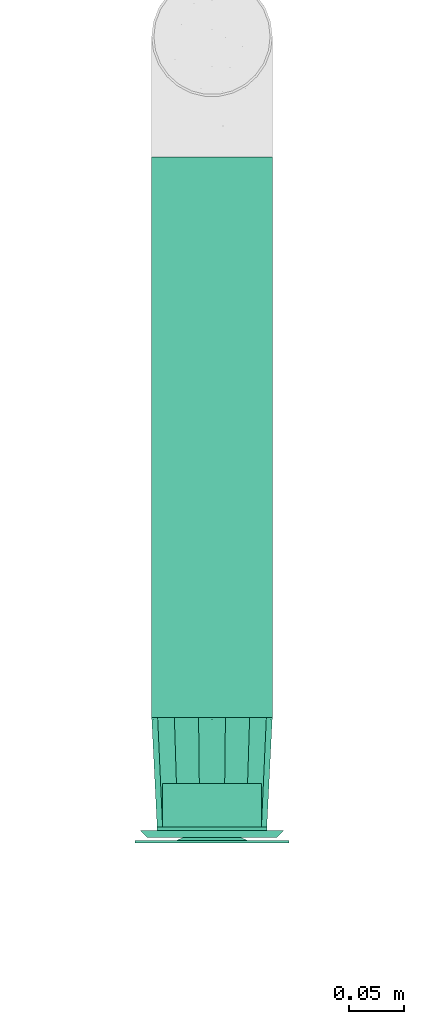
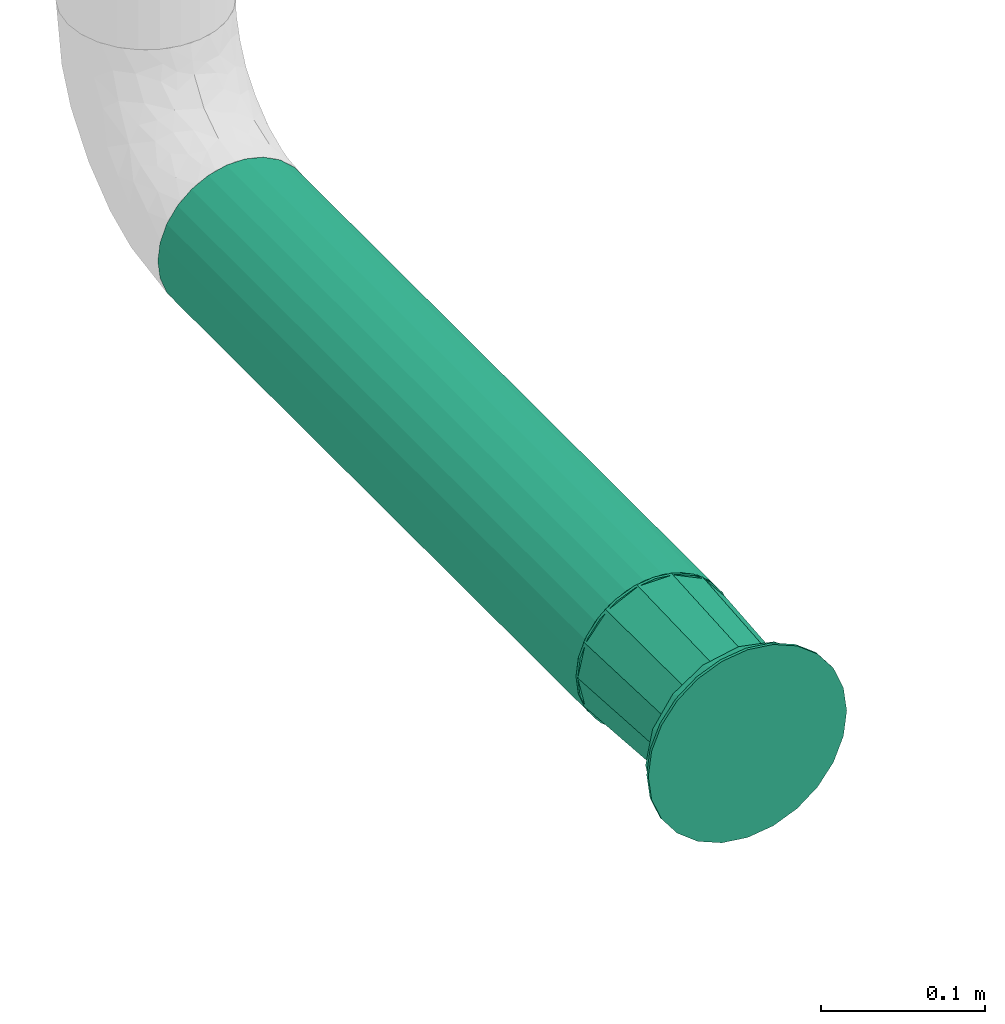
# One storey, part 55 of 123: 1 flow fitting, 1 flow segment, 1 flow terminal.
"""IFC2X3 building model written with IfcOpenShell, lengths in millimetres."""

from ifc_helpers import new_model, entity, si_unit, converted_unit, derived_unit, direction, frame, origin_with_axes, origin_2d_with_axis, place, context, subcontext, project, spatial, hollow_circle, extrude, open_shell, surface_model, source, transform, mapped, material, layer, layer_set, layer_usage, type_object, element, save


model = new_model("IFC2X3")

# Units and contexts
model_context = context("Model", 3, precision=1e-05, world=origin_with_axes(), true_north=direction((0.0, 1.0)))
body_context = subcontext(model_context, "Body", "Model", "MODEL_VIEW")
ifc_project = project(units=[si_unit("AREAUNIT", "SQUARE_METRE"), si_unit("VOLUMEUNIT", "CUBIC_METRE", prefix="DECI"), si_unit("TIMEUNIT", "SECOND"), si_unit("THERMODYNAMICTEMPERATUREUNIT", "DEGREE_CELSIUS"), si_unit("PRESSUREUNIT", "PASCAL"), si_unit("MASSUNIT", "GRAM", prefix="KILO"), si_unit("LENGTHUNIT", "METRE", prefix="MILLI"), si_unit("POWERUNIT", "WATT"), si_unit("ELECTRICCURRENTUNIT", "AMPERE"), si_unit("ELECTRICVOLTAGEUNIT", "VOLT"), derived_unit("VOLUMETRICFLOWRATEUNIT", [(si_unit("VOLUMEUNIT", "CUBIC_METRE", prefix="DECI"), 1), (si_unit("TIMEUNIT", "SECOND"), -1)]), derived_unit("LINEARVELOCITYUNIT", [(si_unit("LENGTHUNIT", "METRE"), 1), (si_unit("TIMEUNIT", "SECOND"), -1)]), derived_unit("MASSDENSITYUNIT", [(si_unit("MASSUNIT", "GRAM", prefix="KILO"), 1), (si_unit("VOLUMEUNIT", "CUBIC_METRE"), -1)]), converted_unit("PLANEANGLEUNIT", "DEGREE", entity("IfcRatioMeasure", 0.01745), si_unit("PLANEANGLEUNIT", "RADIAN"), dimensions=[0, 0, 0, 0, 0, 0, 0])], contexts=[model_context])

# Site, building, storey
site_placement = place(None, origin_with_axes())
site = spatial("IfcSite", under=ifc_project, at=site_placement, CompositionType="ELEMENT")
building_placement = place(site_placement, origin_with_axes())
building = spatial("IfcBuilding", under=site, at=building_placement, Name="mc-building", CompositionType="ELEMENT")
storey_placement = place(building_placement, origin_with_axes())
storey = spatial("IfcBuildingStorey", under=building, at=storey_placement, Name="1. Korrus", CompositionType="ELEMENT", Elevation=0.0)

# Flow terminal
air_terminal_type = type_object("IfcAirTerminalType", Name="100", PredefinedType="NOTDEFINED")
shared_shape_1 = source(origin_with_axes(), body_context, "Body", "SurfaceModel", [
    surface_model("IfcShellBasedSurfaceModel", [(11.2, 18.11733, -67.61481), (11.2, -18.11733, -67.61481), (11.2, 0.0, -70.0), (11.2, 67.61481, -18.11733), (11.2, 35.0, -60.62178), (11.2, 49.49747, -49.49747), (11.2, 60.62178, -35.0), (11.2, -67.61481, 18.11733), (11.2, -49.49747, -49.49747), (11.2, -67.61481, -18.11733), (11.2, -35.0, -60.62178), (11.2, -60.62178, -35.0), (11.2, -70.0, 0.0), (11.2, 18.11733, 67.61481), (11.2, 70.0, 0.0), (11.2, 67.61481, 18.11733), (11.2, 49.49747, 49.49747), (11.2, 60.62178, 35.0), (11.2, 35.0, 60.62178), (11.2, -49.49747, 49.49747), (11.2, -60.62178, 35.0), (11.2, -35.0, 60.62178), (11.2, -18.11733, 67.61481), (11.2, 0.0, 70.0), (9.2, 18.11733, 67.61481), (9.2, -67.61481, 18.11733), (9.2, 0.0, 70.0), (9.2, 49.49747, 49.49747), (9.2, 35.0, 60.62178), (9.2, 60.62178, 35.0), (9.2, 67.61481, 18.11733), (9.2, -35.0, 60.62178), (9.2, -49.49747, 49.49747), (9.2, -18.11733, 67.61481), (9.2, -60.62178, 35.0), (9.2, -67.61481, -18.11733), (9.2, -70.0, 0.0), (9.2, 67.61481, -18.11733), (9.2, 18.11733, -67.61481), (9.2, 49.49747, -49.49747), (9.2, 60.62178, -35.0), (9.2, 35.0, -60.62178), (9.2, -18.11733, -67.61481), (9.2, -49.49747, -49.49747), (9.2, -60.62178, -35.0), (9.2, -35.0, -60.62178), (9.2, 0.0, -70.0), (9.2, 70.0, 0.0), (9.2, 32.75, 0.0), (9.2, -16.375, 28.36233), (9.2, -28.36233, 16.375), (9.2, 16.375, 28.36233), (9.2, 0.0, 32.75), (9.2, 28.36233, 16.375), (9.2, -32.75, 0.0), (9.2, -16.375, -28.36233), (9.2, 16.375, -28.36233), (9.2, 0.0, -32.75), (9.2, 28.36233, -16.375), (9.2, -28.36233, -16.375), (6.2, -21.19625, -15.39997), (6.2, -21.19625, 15.39997), (6.2, 8.09625, 24.91768), (6.2, -8.09625, 24.91768), (6.2, -26.2, 0.0), (6.2, 21.19625, 15.39997), (6.2, -8.09625, -24.91768), (6.2, 21.19625, -15.39997), (6.2, 8.09625, -24.91768), (6.2, 26.2, 0.0), (9.2, 31.06579, -6.28555), (6.2, 23.69812, -7.69999), (6.2, -14.64625, -20.15883), (9.2, -22.36867, -22.36867), (6.2, -23.69812, -7.69999), (9.2, -31.06579, -6.28555), (6.2, 14.64625, -20.15883), (9.2, 8.1875, -30.55617), (6.2, 0.0, -24.91768), (9.2, 22.36867, -22.36867), (9.2, -8.1875, -30.55617), (9.2, -31.06579, 6.28555), (6.2, -23.69812, 7.69999), (6.2, 14.64625, 20.15883), (9.2, 22.36867, 22.36867), (6.2, 23.69812, 7.69999), (9.2, 31.06579, 6.28555), (6.2, -14.64625, 20.15883), (9.2, -8.1875, 30.55617), (6.2, 0.0, 24.91768), (9.2, -22.36867, 22.36867), (9.2, 8.1875, 30.55617), (6.2, -13.11761, 57.472), (6.2, -36.75472, 46.08897), (6.2, -53.11211, 25.57744), (6.2, 36.75472, 46.08897), (6.2, -58.95, 0.0), (6.2, 13.11761, 57.472), (6.2, 53.11211, 25.57744), (6.2, -53.11211, -25.57744), (6.2, -36.75472, -46.08897), (6.2, -13.11761, -57.472), (6.2, 58.95, 0.0), (6.2, 53.11211, -25.57744), (6.2, 13.11761, -57.472), (6.2, 36.75472, -46.08897), (0.0, -60.51411, 25.06576), (0.0, 0.0, 65.5), (0.0, 25.06576, 60.51411), (0.0, 46.3155, 46.3155), (0.0, 60.51411, 25.06576), (0.0, -46.3155, 46.3155), (0.0, -25.06576, 60.51411), (0.0, 0.0, -65.5), (0.0, -65.5, 0.0), (0.0, 65.5, 0.0), (0.0, 60.51411, -25.06576), (0.0, 46.3155, -46.3155), (0.0, 25.06576, -60.51411), (0.0, -46.3155, -46.3155), (0.0, -60.51411, -25.06576), (0.0, -25.06576, -60.51411), (6.2, 56.03105, -12.78872), (0.0, 53.4148, -35.69063), (0.0, 35.69063, -53.4148), (6.2, 24.93616, -51.78048), (0.0, -12.53288, -63.00706), (6.2, 0.0, -57.472), (0.0, -35.69063, -53.4148), (0.0, 63.00706, -12.53288), (6.2, 44.93342, -35.83321), (6.2, -24.93616, -51.78048), (6.2, -44.93342, -35.83321), (0.0, -53.4148, -35.69063), (0.0, 12.53288, -63.00706), (6.2, -56.03105, -12.78872), (0.0, -63.00706, -12.53288), (6.2, -56.03105, 12.78872), (0.0, -53.4148, 35.69063), (0.0, -35.69063, 53.4148), (6.2, -24.93616, 51.78048), (0.0, 12.53288, 63.00706), (6.2, 0.0, 57.472), (0.0, 35.69063, 53.4148), (0.0, -63.00706, 12.53288), (6.2, -44.93342, 35.83321), (6.2, 24.93616, 51.78048), (6.2, 44.93342, 35.83321), (0.0, 53.4148, 35.69063), (0.0, -12.53288, 63.00706), (6.2, 56.03105, 12.78872), (0.0, 63.00706, 12.53288), (-3.1, 12.94095, 48.29629), (-3.1, -35.35534, 35.35534), (-3.1, 0.0, 50.0), (-3.1, 35.35534, 35.35534), (-3.1, 25.0, 43.30127), (-3.1, -43.30127, 25.0), (-3.1, 43.30127, 25.0), (-3.1, -48.29629, -12.94095), (-3.1, -12.94095, 48.29629), (-3.1, -25.0, 43.30127), (-3.1, -50.0, 0.0), (-3.1, -48.29629, 12.94095), (-3.1, 48.29629, 12.94095), (-3.1, 12.94095, -48.29629), (-3.1, 50.0, 0.0), (-3.1, 48.29629, -12.94095), (-3.1, 35.35534, -35.35534), (-3.1, 43.30127, -25.0), (-3.1, 25.0, -43.30127), (-3.1, 0.0, -50.0), (-3.1, -35.35534, -35.35534), (-3.1, -43.30127, -25.0), (-3.1, -25.0, -43.30127), (-3.1, -12.94095, -48.29629), (0.0, 25.0, -43.30127), (0.0, 0.0, -50.0), (0.0, 12.94095, -48.29629), (0.0, 48.29629, -12.94095), (0.0, 35.35534, -35.35534), (0.0, -25.0, -43.30127), (0.0, 43.30127, -25.0), (0.0, -50.0, 0.0), (0.0, -12.94095, -48.29629), (0.0, -35.35534, -35.35534), (0.0, -48.29629, -12.94095), (0.0, -43.30127, -25.0), (0.0, 50.0, 0.0), (0.0, 43.30127, 25.0), (0.0, 12.94095, 48.29629), (0.0, 35.35534, 35.35534), (0.0, 25.0, 43.30127), (0.0, 0.0, 50.0), (0.0, -35.35534, 35.35534), (0.0, -43.30127, 25.0), (0.0, -48.29629, 12.94095), (0.0, -12.94095, 48.29629), (0.0, -25.0, 43.30127), (0.0, 48.29629, 12.94095), (-43.1, 0.0, 45.0), (-43.1, 11.64686, 43.46666), (-43.1, 22.5, 38.97115), (-43.1, -11.64686, 43.46666), (-43.1, 38.97115, 22.5), (-43.1, 43.46666, 11.64686), (-43.1, 31.81981, 31.81981), (-43.1, -22.5, 38.97115), (-43.1, -43.46666, 11.64686), (-43.1, -31.81981, 31.81981), (-43.1, -38.97115, 22.5), (-43.1, -45.0, 0.0), (-43.1, -43.46666, -11.64686), (-43.1, 45.0, 0.0), (-43.1, 43.46666, -11.64686), (-43.1, 38.97115, -22.5), (-43.1, 31.81981, -31.81981), (-43.1, 22.5, -38.97115), (-43.1, 11.64686, -43.46666), (-43.1, -31.81981, -31.81981), (-43.1, -38.97115, -22.5), (-43.1, -22.5, -38.97115), (-43.1, 0.0, -45.0), (-43.1, -11.64686, -43.46666), (-3.1, 22.5, -38.97115), (-3.1, 0.0, -45.0), (-3.1, 11.64686, -43.46666), (-3.1, 31.81981, -31.81981), (-3.1, -22.5, -38.97115), (-3.1, 38.97115, -22.5), (-3.1, 43.46666, -11.64686), (-3.1, 45.0, 0.0), (-3.1, -45.0, 0.0), (-3.1, -11.64686, -43.46666), (-3.1, -31.81981, -31.81981), (-3.1, -43.46666, -11.64686), (-3.1, -38.97115, -22.5), (-3.1, 0.0, 45.0), (-3.1, 43.46666, 11.64686), (-3.1, 38.97115, 22.5), (-3.1, 22.5, 38.97115), (-3.1, 31.81981, 31.81981), (-3.1, 11.64686, 43.46666), (-3.1, -11.64686, 43.46666), (-3.1, -43.46666, 11.64686), (-3.1, -31.81981, 31.81981), (-3.1, -38.97115, 22.5), (-3.1, -22.5, 38.97115)], [open_shell([[[0, 1, 2]], [[3, 0, 4]], [[5, 6, 3]], [[5, 3, 4]], [[7, 1, 0]], [[8, 7, 9]], [[10, 7, 8]], [[8, 9, 11]], [[12, 9, 7]], [[1, 7, 10]], [[7, 0, 3]], [[13, 14, 15]], [[16, 15, 17]], [[16, 18, 13]], [[16, 13, 15]], [[14, 13, 7]], [[7, 19, 20]], [[19, 7, 21]], [[7, 22, 21]], [[22, 7, 23]], [[7, 13, 23]], [[14, 7, 3]], [[24, 25, 26]], [[27, 24, 28]], [[27, 29, 30]], [[27, 30, 24]], [[25, 24, 30]], [[31, 25, 32]], [[25, 31, 33]], [[32, 25, 34]], [[33, 26, 25]], [[25, 35, 36]], [[25, 30, 37]], [[25, 37, 38]], [[39, 37, 40]], [[39, 41, 38]], [[39, 38, 37]], [[38, 42, 25]], [[35, 43, 44]], [[35, 25, 43]], [[45, 43, 25]], [[42, 45, 25]], [[38, 46, 42]], [[37, 30, 47]], [[35, 9, 36]], [[44, 11, 35]], [[10, 43, 45]], [[44, 43, 8]], [[1, 45, 42]], [[35, 11, 9]], [[9, 12, 36]], [[1, 10, 45]], [[8, 43, 10]], [[8, 11, 44]], [[2, 1, 42]], [[42, 46, 2]], [[38, 0, 46]], [[41, 4, 38]], [[6, 39, 40]], [[41, 39, 5]], [[3, 40, 37]], [[41, 5, 4]], [[4, 0, 38]], [[14, 3, 37]], [[6, 40, 3]], [[6, 5, 39]], [[47, 14, 37]], [[46, 0, 2]], [[30, 15, 47]], [[29, 17, 30]], [[18, 27, 28]], [[29, 27, 16]], [[13, 28, 24]], [[30, 17, 15]], [[15, 14, 47]], [[13, 18, 28]], [[16, 27, 18]], [[16, 17, 29]], [[23, 13, 24]], [[24, 26, 23]], [[33, 22, 26]], [[31, 21, 33]], [[20, 32, 34]], [[31, 32, 19]], [[7, 34, 25]], [[31, 19, 21]], [[21, 22, 33]], [[12, 7, 25]], [[20, 34, 7]], [[20, 19, 32]], [[36, 12, 25]], [[26, 22, 23]], [[48, 49, 50]], [[48, 51, 49]], [[49, 51, 52]], [[53, 51, 48]], [[48, 50, 54]], [[54, 55, 48]], [[56, 55, 57]], [[55, 58, 48]], [[58, 55, 56]], [[55, 54, 59]], [[60, 61, 62]], [[62, 61, 63]], [[64, 61, 60]], [[62, 65, 66]], [[67, 68, 65]], [[66, 60, 62]], [[65, 68, 66]], [[69, 67, 65]], [[69, 48, 70]], [[58, 71, 70]], [[72, 73, 60]], [[59, 74, 60]], [[75, 64, 74]], [[56, 68, 76]], [[72, 66, 55]], [[73, 72, 55]], [[68, 77, 78]], [[64, 75, 54]], [[59, 75, 74]], [[70, 71, 69]], [[67, 79, 76]], [[80, 55, 66]], [[68, 56, 77]], [[56, 76, 79]], [[79, 67, 58]], [[71, 58, 67]], [[80, 78, 57]], [[77, 57, 78]], [[66, 78, 80]], [[59, 60, 73]], [[64, 54, 81]], [[50, 82, 81]], [[83, 84, 65]], [[53, 85, 65]], [[86, 69, 85]], [[49, 63, 87]], [[83, 62, 51]], [[84, 83, 51]], [[63, 88, 89]], [[69, 86, 48]], [[53, 86, 85]], [[81, 82, 64]], [[61, 90, 87]], [[91, 51, 62]], [[63, 49, 88]], [[49, 87, 90]], [[90, 61, 50]], [[82, 50, 61]], [[91, 89, 52]], [[88, 52, 89]], [[62, 89, 91]], [[53, 65, 84]], [[92, 93, 94]], [[95, 94, 96]], [[97, 92, 95]], [[95, 92, 94]], [[96, 98, 95]], [[96, 99, 98]], [[99, 100, 101]], [[101, 102, 98]], [[102, 101, 103]], [[104, 105, 103]], [[101, 104, 103]], [[101, 98, 99]], [[106, 107, 108]], [[109, 110, 108]], [[106, 108, 110]], [[111, 112, 106]], [[106, 112, 107]], [[106, 113, 114]], [[106, 110, 113]], [[115, 116, 117]], [[117, 113, 110]], [[113, 117, 118]], [[114, 119, 120]], [[121, 119, 114]], [[121, 114, 113]], [[115, 117, 110]], [[103, 116, 122]], [[123, 116, 103]], [[124, 125, 118]], [[101, 126, 127]], [[100, 119, 128]], [[102, 122, 129]], [[103, 130, 123]], [[102, 129, 115]], [[113, 127, 126]], [[125, 124, 105]], [[130, 105, 117]], [[118, 125, 104]], [[124, 117, 105]], [[131, 100, 128]], [[119, 100, 132]], [[133, 99, 120]], [[134, 118, 104]], [[122, 116, 129]], [[127, 134, 104]], [[131, 121, 101]], [[99, 133, 132]], [[128, 121, 131]], [[130, 117, 123]], [[101, 121, 126]], [[99, 135, 120]], [[96, 136, 135]], [[136, 120, 135]], [[134, 127, 113]], [[133, 119, 132]], [[136, 96, 114]], [[94, 106, 137]], [[138, 106, 94]], [[139, 140, 112]], [[97, 141, 142]], [[95, 109, 143]], [[96, 137, 144]], [[94, 145, 138]], [[96, 144, 114]], [[107, 142, 141]], [[140, 139, 93]], [[145, 93, 111]], [[112, 140, 92]], [[139, 111, 93]], [[146, 95, 143]], [[109, 95, 147]], [[148, 98, 110]], [[149, 112, 92]], [[137, 106, 144]], [[142, 149, 92]], [[146, 108, 97]], [[98, 148, 147]], [[143, 108, 146]], [[145, 111, 138]], [[97, 108, 141]], [[98, 150, 110]], [[102, 151, 150]], [[151, 110, 150]], [[149, 142, 107]], [[148, 109, 147]], [[151, 102, 115]], [[152, 153, 154]], [[155, 152, 156]], [[157, 152, 158]], [[158, 152, 155]], [[158, 159, 157]], [[160, 153, 161]], [[160, 154, 153]], [[157, 162, 163]], [[153, 152, 157]], [[157, 159, 162]], [[158, 164, 159]], [[165, 166, 167]], [[168, 167, 169]], [[170, 165, 167]], [[170, 167, 168]], [[166, 165, 171]], [[159, 172, 173]], [[172, 159, 174]], [[174, 171, 175]], [[159, 164, 174]], [[166, 171, 174]], [[174, 164, 166]], [[176, 177, 178]], [[179, 176, 180]], [[176, 179, 181]], [[179, 180, 182]], [[179, 183, 181]], [[177, 181, 184]], [[177, 176, 181]], [[185, 186, 187]], [[186, 185, 181]], [[181, 183, 186]], [[183, 179, 188]], [[183, 188, 189]], [[190, 189, 191]], [[189, 190, 183]], [[190, 191, 192]], [[193, 194, 190]], [[183, 195, 196]], [[183, 190, 195]], [[194, 197, 198]], [[194, 195, 190]], [[197, 194, 193]], [[189, 188, 199]], [[164, 199, 166]], [[158, 189, 164]], [[192, 155, 156]], [[158, 155, 191]], [[190, 156, 152]], [[164, 189, 199]], [[199, 188, 166]], [[190, 192, 156]], [[191, 155, 192]], [[191, 189, 158]], [[193, 190, 152]], [[152, 154, 193]], [[160, 197, 154]], [[161, 198, 160]], [[195, 153, 157]], [[161, 153, 194]], [[196, 157, 163]], [[161, 194, 198]], [[198, 197, 160]], [[183, 196, 163]], [[195, 157, 196]], [[195, 194, 153]], [[162, 183, 163]], [[154, 197, 193]], [[159, 186, 162]], [[173, 187, 159]], [[181, 172, 174]], [[173, 172, 185]], [[184, 174, 175]], [[159, 187, 186]], [[186, 183, 162]], [[184, 181, 174]], [[185, 172, 181]], [[185, 187, 173]], [[177, 184, 175]], [[175, 171, 177]], [[165, 178, 171]], [[170, 176, 165]], [[182, 168, 169]], [[170, 168, 180]], [[179, 169, 167]], [[170, 180, 176]], [[176, 178, 165]], [[188, 179, 167]], [[182, 169, 179]], [[182, 180, 168]], [[166, 188, 167]], [[171, 178, 177]], [[200, 201, 202]], [[203, 200, 202]], [[204, 205, 202]], [[204, 202, 206]], [[203, 202, 205]], [[207, 208, 209]], [[207, 203, 205]], [[209, 208, 210]], [[211, 208, 212]], [[208, 207, 212]], [[207, 205, 212]], [[213, 214, 215]], [[205, 215, 212]], [[212, 216, 217]], [[216, 212, 215]], [[218, 219, 217]], [[212, 219, 220]], [[212, 217, 219]], [[221, 222, 223]], [[222, 221, 219]], [[218, 222, 219]], [[215, 205, 213]], [[224, 225, 226]], [[227, 228, 224]], [[229, 230, 231]], [[228, 227, 229]], [[229, 232, 228]], [[225, 228, 233]], [[225, 224, 228]], [[234, 235, 236]], [[235, 234, 228]], [[228, 232, 235]], [[232, 229, 231]], [[237, 238, 239]], [[240, 239, 241]], [[240, 242, 237]], [[240, 237, 239]], [[238, 237, 243]], [[244, 245, 246]], [[247, 244, 232]], [[244, 247, 245]], [[232, 238, 247]], [[238, 243, 247]], [[238, 232, 231]], [[205, 238, 213]], [[204, 239, 205]], [[240, 206, 202]], [[204, 206, 241]], [[242, 202, 201]], [[205, 239, 238]], [[238, 231, 213]], [[240, 202, 242]], [[241, 206, 240]], [[241, 239, 204]], [[201, 237, 242]], [[201, 200, 237]], [[243, 203, 207]], [[209, 247, 207]], [[246, 210, 208]], [[209, 210, 245]], [[244, 208, 211]], [[203, 243, 200]], [[207, 247, 243]], [[200, 243, 237]], [[209, 245, 247]], [[210, 246, 245]], [[244, 246, 208]], [[211, 232, 244]], [[212, 235, 211]], [[220, 236, 212]], [[228, 219, 221]], [[220, 219, 234]], [[233, 221, 223]], [[212, 236, 235]], [[235, 232, 211]], [[233, 228, 221]], [[234, 219, 228]], [[234, 236, 220]], [[225, 233, 223]], [[223, 222, 225]], [[226, 218, 217]], [[216, 224, 217]], [[229, 215, 214]], [[216, 215, 227]], [[230, 214, 213]], [[218, 226, 222]], [[217, 224, 226]], [[222, 226, 225]], [[216, 227, 224]], [[215, 229, 227]], [[230, 229, 214]], [[213, 231, 230]]])]),
])
flow_terminal_placement = place(storey_placement, frame((8766.57414, 12939.66532, 2300.0), z_axis=(0.0, 0.0, 1.0), x_axis=(0.0, -1.0, 0.0)))
element("IfcFlowTerminal", 1, at=flow_terminal_placement, inside=storey, type_object=air_terminal_type, Name="100", context=body_context, shape_type="MappedRepresentation", body=[
    mapped(shared_shape_1, transform((0.0, 0.0, 0.0), scale=1.0)),
])

# Flow segment
ifc_material = material(Name="FZ1")
ifc_layer = layer(ifc_material, 0.0)
ifc_layer_set = layer_set([ifc_layer], Name="FZ1")
ifc_layer_usage = layer_usage(ifc_layer_set, "AXIS1", "POSITIVE", 0.0)
duct_segment_type = type_object("IfcDuctSegmentType", PredefinedType="RIGIDSEGMENT")
shared_shape_2 = source(origin_with_axes(), body_context, "Body", "SweptSolid", [
    extrude(hollow_circle(Radius=55.0, WallThickness=2.0, at=origin_2d_with_axis()), frame((0.0, 0.0, 0.0), z_axis=(1.0, 0.0, 0.0), x_axis=(0.0, 1.0, 0.0)), (0.0, 0.0, 1.0), 510.8),
])
flow_segment_placement = place(storey_placement, frame((8766.57414, 13042.76532, 2300.0), z_axis=(0.0, 0.0, 1.0), x_axis=(0.0, 1.0, 0.0)))
element("IfcFlowSegment", 2, at=flow_segment_placement, inside=storey, type_object=duct_segment_type, material=ifc_layer_usage, context=body_context, shape_type="MappedRepresentation", body=[
    mapped(shared_shape_2, transform((0.0, 0.0, 0.0), scale=1.0)),
])

# Flow fitting
duct_fitting_type = type_object("IfcDuctFittingType", PredefinedType="TRANSITION")
shared_shape_3 = source(origin_with_axes(), body_context, "Body", "SurfaceModel", [
    surface_model("IfcShellBasedSurfaceModel", [(0.0, 12.94095, 48.29629), (0.0, -35.35534, 35.35534), (0.0, 0.0, 50.0), (0.0, 35.35534, 35.35534), (0.0, 25.0, 43.30127), (0.0, 43.30127, 25.0), (0.0, 48.29629, 12.94095), (0.0, -12.94095, 48.29629), (0.0, -25.0, 43.30127), (0.0, -48.29629, 12.94095), (0.0, -43.30127, 25.0), (0.0, -25.0, -43.30127), (0.0, -48.29629, -12.94095), (0.0, -50.0, 0.0), (0.0, 48.29629, -12.94095), (0.0, 12.94095, -48.29629), (0.0, 43.30127, -25.0), (0.0, 35.35534, -35.35534), (0.0, 25.0, -43.30127), (0.0, -35.35534, -35.35534), (0.0, -43.30127, -25.0), (0.0, -12.94095, -48.29629), (0.0, 0.0, -50.0), (0.0, 50.0, 0.0), (100.0, -55.0, 0.0), (100.0, -12.23865, 53.62104), (100.0, -34.29194, 43.00073), (100.0, 49.55329, -23.86361), (100.0, 12.23865, 53.62104), (100.0, 34.29194, 43.00073), (100.0, 55.0, 0.0), (100.0, 49.55329, 23.86361), (100.0, -49.55329, 23.86361), (100.0, 12.23865, -53.62104), (100.0, -49.55329, -23.86361), (100.0, -34.29194, -43.00073), (100.0, 34.29194, -43.00073), (100.0, -12.23865, -53.62104), (0.0, 11.12605, 48.7464), (0.0, -11.12605, 48.7464), (0.0, 31.17449, 39.09157), (0.0, -45.04844, -21.69419), (0.0, -45.04844, 21.69419), (0.0, -31.17449, 39.09157), (0.0, 45.04844, 21.69419), (0.0, 45.04844, -21.69419), (0.0, 31.17449, -39.09157), (0.0, -31.17449, -39.09157), (0.0, -11.12605, -48.7464), (0.0, 11.12605, -48.7464), (0.0, -47.52422, -10.84709), (100.0, -41.92261, -33.43217), (0.0, -38.11147, -30.39288), (100.0, 41.92261, -33.43217), (0.0, 38.11147, -30.39288), (0.0, -21.15027, -43.91899), (100.0, -23.2653, -48.31088), (100.0, -52.32388, -11.72483), (100.0, 0.0, -53.62104), (0.0, 0.0, -48.7464), (100.0, 23.2653, -48.31088), (0.0, 21.15027, -43.91899), (100.0, 52.32388, -11.72483), (0.0, 47.52422, -10.84709), (0.0, 47.52422, 10.84709), (100.0, 41.92261, 33.43217), (0.0, 38.11147, 30.39288), (100.0, -41.92261, 33.43217), (0.0, -38.11147, 30.39288), (0.0, 21.15027, 43.91899), (100.0, 23.2653, 48.31088), (100.0, 52.32388, 11.72483), (100.0, 0.0, 53.62104), (0.0, 0.0, 48.7464), (100.0, -23.2653, 48.31088), (0.0, -21.15027, 43.91899), (100.0, -52.32388, 11.72483), (0.0, -47.52422, 10.84709), (100.0, 27.5, -47.63139), (100.0, 0.0, -55.0), (100.0, 14.23505, -53.12592), (100.0, 38.89087, -38.89087), (100.0, -27.5, -47.63139), (100.0, 47.63139, -27.5), (100.0, 53.12592, -14.23505), (100.0, -14.23505, -53.12592), (100.0, -47.63139, -27.5), (100.0, -38.89087, -38.89087), (100.0, -53.12592, -14.23505), (100.0, 53.12592, 14.23505), (100.0, 47.63139, 27.5), (100.0, 27.5, 47.63139), (100.0, 38.89087, 38.89087), (100.0, 14.23505, 53.12592), (100.0, 0.0, 55.0), (100.0, -47.63139, 27.5), (100.0, -53.12592, 14.23505), (100.0, -27.5, 47.63139), (100.0, -38.89087, 38.89087), (100.0, -14.23505, 53.12592), (98.0, 0.0, 55.0), (98.0, 14.23505, 53.12592), (98.0, 27.5, 47.63139), (98.0, 38.89087, 38.89087), (98.0, 47.63139, 27.5), (98.0, -47.63139, 27.5), (98.0, 53.12592, -14.23505), (98.0, -27.5, 47.63139), (98.0, -14.23505, 53.12592), (98.0, -38.89087, 38.89087), (98.0, -55.0, 0.0), (98.0, -53.12592, 14.23505), (98.0, 53.12592, 14.23505), (98.0, 47.63139, -27.5), (98.0, -27.5, -47.63139), (98.0, 0.0, -55.0), (98.0, 38.89087, -38.89087), (98.0, 27.5, -47.63139), (98.0, 14.23505, -53.12592), (98.0, -47.63139, -27.5), (98.0, -38.89087, -38.89087), (98.0, -53.12592, -14.23505), (98.0, -14.23505, -53.12592), (98.0, 55.0, 0.0), (2.0, 12.94095, -48.29629), (2.0, 25.0, -43.30127), (2.0, 35.35534, -35.35534), (2.0, 43.30127, -25.0), (2.0, 48.29629, -12.94095), (2.0, 0.0, -50.0), (2.0, 50.0, 0.0), (2.0, -25.0, -43.30127), (2.0, -12.94095, -48.29629), (2.0, -35.35534, -35.35534), (2.0, -48.29629, -12.94095), (2.0, -43.30127, -25.0), (2.0, -48.29629, 12.94095), (2.0, 48.29629, 12.94095), (2.0, 43.30127, 25.0), (2.0, 35.35534, 35.35534), (2.0, -35.35534, 35.35534), (2.0, 12.94095, 48.29629), (2.0, 25.0, 43.30127), (2.0, 0.0, 50.0), (2.0, -43.30127, 25.0), (2.0, -50.0, 0.0), (2.0, -12.94095, 48.29629), (2.0, -25.0, 43.30127)], [open_shell([[[0, 1, 2]], [[3, 0, 4]], [[3, 5, 6]], [[0, 3, 1]], [[6, 1, 3]], [[7, 1, 8]], [[7, 2, 1]], [[1, 9, 10]], [[9, 1, 11]], [[12, 13, 9]], [[11, 1, 6]], [[6, 14, 11]], [[15, 14, 16]], [[17, 18, 15]], [[17, 15, 16]], [[11, 14, 15]], [[12, 19, 20]], [[19, 12, 11]], [[15, 21, 11]], [[12, 9, 11]], [[22, 21, 15]], [[14, 6, 23]], [[24, 25, 26]], [[25, 27, 28]], [[29, 28, 27]], [[27, 30, 31]], [[31, 29, 27]], [[24, 26, 32]], [[33, 24, 34]], [[33, 34, 35]], [[36, 27, 33]], [[33, 27, 24]], [[35, 37, 33]], [[24, 27, 25]], [[38, 23, 39]], [[40, 23, 38]], [[41, 42, 43]], [[41, 13, 42]], [[23, 43, 39]], [[40, 44, 23]], [[41, 23, 45]], [[41, 45, 46]], [[47, 41, 48]], [[49, 48, 41]], [[41, 46, 49]], [[23, 41, 43]], [[34, 50, 41]], [[47, 51, 52]], [[45, 27, 53]], [[36, 54, 53]], [[55, 48, 56]], [[34, 57, 50]], [[57, 13, 50]], [[13, 57, 24]], [[55, 35, 47]], [[35, 51, 47]], [[51, 41, 52]], [[58, 59, 49]], [[60, 61, 46]], [[37, 59, 58]], [[62, 63, 23]], [[35, 55, 56]], [[23, 30, 62]], [[53, 54, 45]], [[48, 37, 56]], [[33, 49, 61]], [[49, 33, 58]], [[54, 36, 46]], [[63, 27, 45]], [[34, 41, 51]], [[33, 61, 60]], [[48, 59, 37]], [[27, 63, 62]], [[46, 36, 60]], [[31, 64, 44]], [[40, 65, 66]], [[42, 32, 67]], [[26, 68, 67]], [[69, 38, 70]], [[31, 71, 64]], [[71, 23, 64]], [[23, 71, 30]], [[69, 29, 40]], [[29, 65, 40]], [[65, 44, 66]], [[72, 73, 39]], [[74, 75, 43]], [[28, 73, 72]], [[76, 77, 13]], [[29, 69, 70]], [[13, 24, 76]], [[67, 68, 42]], [[38, 28, 70]], [[25, 39, 75]], [[39, 25, 72]], [[68, 26, 43]], [[77, 32, 42]], [[31, 44, 65]], [[25, 75, 74]], [[38, 73, 28]], [[32, 77, 76]], [[43, 26, 74]], [[78, 79, 80]], [[81, 82, 78]], [[82, 83, 84]], [[81, 83, 82]], [[30, 82, 84]], [[79, 82, 85]], [[79, 78, 82]], [[82, 86, 87]], [[82, 30, 86]], [[24, 88, 86]], [[86, 30, 89]], [[90, 24, 89]], [[91, 90, 92]], [[91, 93, 94]], [[90, 91, 24]], [[94, 95, 91]], [[24, 95, 96]], [[24, 91, 95]], [[94, 97, 98]], [[98, 95, 94]], [[97, 94, 99]], [[89, 24, 86]], [[100, 101, 102]], [[100, 102, 103]], [[100, 104, 105]], [[104, 100, 103]], [[106, 105, 104]], [[100, 107, 108]], [[100, 109, 107]], [[105, 110, 111]], [[109, 100, 105]], [[105, 106, 110]], [[106, 104, 112]], [[106, 113, 110]], [[113, 114, 110]], [[115, 116, 117]], [[113, 116, 115]], [[117, 118, 115]], [[119, 114, 120]], [[121, 110, 119]], [[114, 115, 122]], [[119, 110, 114]], [[115, 114, 113]], [[123, 106, 112]], [[121, 88, 110]], [[119, 86, 121]], [[82, 120, 114]], [[119, 120, 87]], [[85, 114, 122]], [[121, 86, 88]], [[88, 24, 110]], [[85, 82, 114]], [[87, 120, 82]], [[87, 86, 119]], [[79, 85, 122]], [[122, 115, 79]], [[118, 80, 115]], [[117, 78, 118]], [[83, 116, 113]], [[117, 116, 81]], [[84, 113, 106]], [[117, 81, 78]], [[78, 80, 118]], [[30, 84, 106]], [[83, 113, 84]], [[83, 81, 116]], [[123, 30, 106]], [[115, 80, 79]], [[112, 89, 123]], [[104, 90, 112]], [[91, 103, 102]], [[104, 103, 92]], [[93, 102, 101]], [[112, 90, 89]], [[89, 30, 123]], [[93, 91, 102]], [[92, 103, 91]], [[92, 90, 104]], [[94, 93, 101]], [[101, 100, 94]], [[108, 99, 100]], [[107, 97, 108]], [[95, 109, 105]], [[107, 109, 98]], [[96, 105, 111]], [[107, 98, 97]], [[97, 99, 108]], [[24, 96, 111]], [[95, 105, 96]], [[95, 98, 109]], [[110, 24, 111]], [[100, 99, 94]], [[124, 125, 126]], [[124, 126, 127]], [[124, 128, 129]], [[128, 124, 127]], [[129, 128, 130]], [[129, 131, 132]], [[129, 130, 131]], [[133, 134, 135]], [[134, 133, 131]], [[131, 136, 134]], [[131, 130, 137]], [[137, 138, 139]], [[140, 137, 139]], [[140, 139, 141]], [[141, 139, 142]], [[140, 141, 143]], [[136, 140, 144]], [[145, 134, 136]], [[140, 146, 147]], [[131, 140, 136]], [[143, 146, 140]], [[131, 137, 140]], [[12, 134, 13]], [[20, 135, 12]], [[131, 19, 11]], [[20, 19, 133]], [[132, 11, 21]], [[12, 135, 134]], [[134, 145, 13]], [[132, 131, 11]], [[133, 19, 131]], [[133, 135, 20]], [[129, 132, 21]], [[21, 22, 129]], [[15, 124, 22]], [[18, 125, 15]], [[127, 17, 16]], [[18, 17, 126]], [[128, 16, 14]], [[18, 126, 125]], [[125, 124, 15]], [[130, 128, 14]], [[127, 16, 128]], [[127, 126, 17]], [[23, 130, 14]], [[22, 124, 129]], [[6, 137, 23]], [[5, 138, 6]], [[142, 3, 4]], [[5, 3, 139]], [[141, 4, 0]], [[6, 138, 137]], [[137, 130, 23]], [[141, 142, 4]], [[139, 3, 142]], [[139, 138, 5]], [[143, 141, 0]], [[0, 2, 143]], [[7, 146, 2]], [[8, 147, 7]], [[144, 1, 10]], [[8, 1, 140]], [[136, 10, 9]], [[8, 140, 147]], [[147, 146, 7]], [[145, 136, 9]], [[144, 10, 136]], [[144, 140, 1]], [[13, 145, 9]], [[2, 146, 143]]])]),
])
flow_fitting_placement = place(storey_placement, frame((8766.57414, 12942.76532, 2300.0), z_axis=(0.0, 0.0, 1.0), x_axis=(0.0, 1.0, 0.0)))
element("IfcFlowFitting", 3, at=flow_fitting_placement, inside=storey, type_object=duct_fitting_type, context=body_context, shape_type="MappedRepresentation", body=[
    mapped(shared_shape_3, transform((0.0, 0.0, 0.0), scale=1.0)),
])

save(model, "model.ifc")
